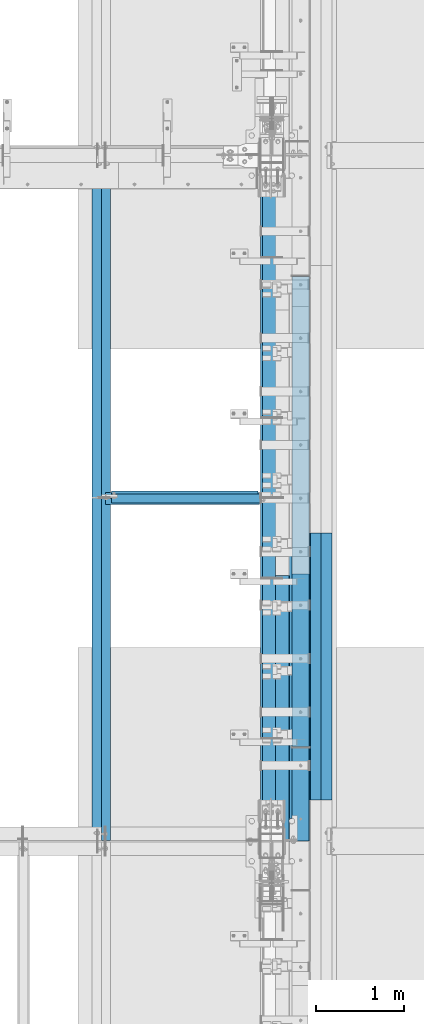
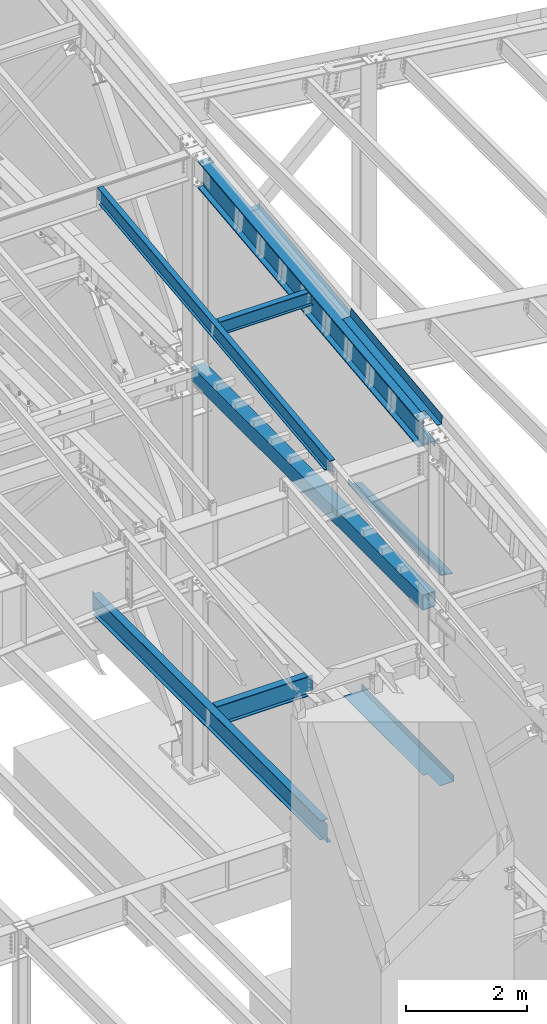
# One storey, part 736 of 1179: 12 beams, 10 elements without a shape of their own.
"""IFC2X3 building model written with IfcOpenShell, lengths in millimetres."""

from ifc_helpers import new_model, si_unit, frame, origin_with_axes, place, context, subcontext, project, spatial, faceted_brep, material, type_object, element, aggregate, save


model = new_model("IFC2X3")

# Units and contexts
model_context = context("Model", 3, precision=1e-05, world=origin_with_axes())
body_context = subcontext(model_context, "Body", "Model", "MODEL_VIEW")
ifc_project = project(units=[si_unit("LENGTHUNIT", "METRE", prefix="MILLI"), si_unit("AREAUNIT", "SQUARE_METRE"), si_unit("VOLUMEUNIT", "CUBIC_METRE"), si_unit("MASSUNIT", "GRAM", prefix="KILO"), si_unit("TIMEUNIT", "SECOND"), si_unit("PLANEANGLEUNIT", "RADIAN"), si_unit("SOLIDANGLEUNIT", "STERADIAN"), si_unit("THERMODYNAMICTEMPERATUREUNIT", "DEGREE_CELSIUS"), si_unit("LUMINOUSINTENSITYUNIT", "LUMEN")], contexts=[model_context])

# Site, building, storey
site_placement = place(None, origin_with_axes())
site = spatial("IfcSite", under=ifc_project, at=site_placement, CompositionType="ELEMENT")
building_placement = place(site_placement, origin_with_axes())
building = spatial("IfcBuilding", under=site, at=building_placement, Name="Undefined", CompositionType="ELEMENT")
storey_placement = place(building_placement, origin_with_axes())
storey = spatial("IfcBuildingStorey", under=building, at=storey_placement, Name="Undefined", CompositionType="ELEMENT", Elevation=0.0)

# Assembly, beam
assembly_1_placement = place(storey_placement, origin_with_axes())
assembly_1 = element("IfcElementAssembly", 1, at=assembly_1_placement, inside=storey, Name="BEAM", AssemblyPlace="NOTDEFINED", PredefinedType="RIGID_FRAME")
ifc_material_1 = material(Name="STEEL/A992")
beam_type_1 = type_object("IfcBeamType", Name="W16X31", PredefinedType="NOTDEFINED")
beam_1_placement = place(assembly_1_placement, frame((22329.775, 23139.4, 3900.4875), z_axis=(0.0, 0.0, 1.0), x_axis=(1.0, 0.0, 0.0)))
beam_1 = element("IfcBeam", 2, at=beam_1_placement, type_object=beam_type_1, material=ifc_material_1, Name="BEAM", ObjectType="W16X31", context=body_context, shape_type="Brep", body=[
    faceted_brep([(12.7000000000007, -3.17499999999927, -169.8625), (12.7000000000007, 3.17499999999927, -169.8625), (66.6750001907276, 3.17499999999927, -169.8625), (66.6750001907276, -3.17499999999927, -169.8625), (71.535079708774, 3.17499999999927, -170.829229922588), (71.535079708774, -3.17499999999927, -170.829229922588), (75.6552561769277, 3.17499999999927, -173.582243823066), (75.6552561769277, -3.17499999999927, -173.582243823066), (78.4082700774052, 3.17499999999927, -177.70242029122), (78.4082700774052, -3.17499999999927, -177.70242029122), (79.3749999999927, -3.17499999999927, -182.562499809265), (79.3749999999927, 3.17499999999927, -182.562499809265), (79.3749999999927, 3.17499999999927, -190.5), (79.3749999999927, 69.8499999999985, -190.5), (79.3749999999927, 69.8499999999985, -201.6125), (79.3749999999927, -69.8499999999985, -201.6125), (79.3749999999927, -69.8499999999985, -190.5), (79.3749999999927, -3.17499999999927, -190.5), (1835.94375, 69.8499999999985, 190.5), (1835.94375, 3.17499999999927, 190.5), (79.3749999999927, 3.17499999999927, 190.5), (79.3749999999927, 69.8499999999985, 190.5), (66.6750001907276, -3.17499999999927, 169.8625), (66.6750001907276, 3.17499999999927, 169.8625), (12.7000000000007, 3.17499999999927, 169.8625), (12.7000000000007, -3.17499999999927, 169.8625), (71.535079708774, -3.17499999999927, 170.829229922588), (71.535079708774, 3.17499999999927, 170.829229922588), (75.6552561769277, -3.17499999999927, 173.582243823066), (75.6552561769277, 3.17499999999927, 173.582243823066), (78.4082700774052, -3.17499999999927, 177.702420291219), (78.4082700774052, 3.17499999999927, 177.702420291219), (79.3749999999927, -3.17499999999927, 182.562499809265), (79.3749999999927, 3.17499999999927, 182.562499809265), (1835.94375, -69.8499999999985, 201.6125), (1835.94375, 69.8499999999985, 201.6125), (79.3749999999927, 69.8499999999985, 201.6125), (79.3749999999927, -69.8499999999985, 201.6125), (1835.94375, -69.8499999999985, 190.5), (79.3749999999927, -69.8499999999985, 190.5), (1835.94375, -3.17499999999927, 190.5), (79.3749999999927, -3.17499999999927, 190.5), (1835.94375, -3.17499999999927, 169.862499809265), (1835.94375, 3.17499999999927, 169.862499809265), (1836.91047992259, -3.17499999999927, 165.00242029122), (1836.91047992259, 3.17499999999927, 165.00242029122), (1839.66349382306, -3.17499999999927, 160.882243823066), (1839.66349382306, 3.17499999999927, 160.882243823066), (1843.78367029122, -3.17499999999927, 158.129229922588), (1843.78367029122, 3.17499999999927, 158.129229922588), (1848.64374980926, -3.17499999999927, 157.1625), (1848.64374980926, 3.17499999999927, 157.1625), (1959.76875, -3.17499999999927, 157.1625), (1959.76875, 3.17499999999927, 157.1625), (1959.76875, -3.17499999999927, -157.1625), (1959.76875, 3.17499999999927, -157.1625), (1848.64374980926, -3.17499999999927, -157.1625), (1848.64374980926, 3.17499999999927, -157.1625), (1843.78367029122, -3.17499999999927, -158.129229922588), (1843.78367029122, 3.17499999999927, -158.129229922588), (1839.66349382306, -3.17499999999927, -160.882243823066), (1839.66349382306, 3.17499999999927, -160.882243823066), (1836.91047992259, -3.17499999999927, -165.00242029122), (1836.91047992259, 3.17499999999927, -165.00242029122), (1835.94375, -3.17499999999927, -169.862499809266), (1835.94375, 3.17499999999927, -169.862499809266), (1835.94375, -3.17499999999927, -190.5), (1835.94375, -69.8499999999985, -190.5), (1835.94375, -69.8499999999985, -201.6125), (1835.94375, 69.8499999999985, -201.6125), (1835.94375, 69.8499999999985, -190.5), (1835.94375, 3.17499999999927, -190.5)], [[[0, 1, 2, 3]], [[3, 2, 4, 5]], [[5, 4, 6, 7]], [[7, 6, 8, 9]], [[10, 11, 12, 13, 14, 15, 16, 17]], [[9, 8, 11, 10]], [[18, 19, 20, 21]], [[22, 23, 24, 25]], [[26, 27, 23, 22]], [[28, 29, 27, 26]], [[30, 31, 29, 28]], [[32, 33, 31, 30]], [[34, 35, 36, 37]], [[38, 34, 37, 39]], [[40, 38, 39, 41]], [[37, 36, 21, 20, 33, 32, 41, 39]], [[35, 18, 21, 36]], [[34, 38, 40, 42, 43, 19, 18, 35]], [[44, 45, 43, 42]], [[46, 47, 45, 44]], [[48, 49, 47, 46]], [[50, 51, 49, 48]], [[52, 53, 51, 50]], [[53, 52, 54, 55]], [[54, 56, 57, 55]], [[58, 59, 57, 56]], [[60, 61, 59, 58]], [[62, 63, 61, 60]], [[64, 65, 63, 62]], [[66, 67, 68, 69, 70, 71, 65, 64]], [[67, 66, 17, 16]], [[68, 67, 16, 15]], [[69, 68, 15, 14]], [[70, 69, 14, 13]], [[71, 70, 13, 12]], [[6, 4, 2, 1, 24, 23, 27, 29, 31, 33, 20, 19, 43, 45, 47, 49, 51, 53, 55, 57, 59, 61, 63, 65, 71, 12, 11, 8]], [[25, 24, 1, 0]], [[66, 64, 62, 60, 58, 56, 54, 52, 50, 48, 46, 44, 42, 40, 41, 32, 30, 28, 26, 22, 25, 0, 3, 5, 7, 9, 10, 17]]]),
])
aggregate(assembly_1, [beam_1])

assembly_2_placement = place(storey_placement, origin_with_axes())
assembly_2 = element("IfcElementAssembly", 3, at=assembly_2_placement, inside=storey, Name="BEAM", AssemblyPlace="NOTDEFINED", PredefinedType="RIGID_FRAME")
beam_2_placement = place(assembly_2_placement, frame((22326.6, 19227.8, 3900.4875), z_axis=(0.0, 0.0, 1.0), x_axis=(0.0, 1.0, 0.0)))
beam_2 = element("IfcBeam", 4, at=beam_2_placement, type_object=beam_type_1, material=ifc_material_1, Name="BEAM", ObjectType="W16X31", context=body_context, shape_type="Brep", body=[
    faceted_brep([(113.506251936145, -3.17499999997744, 169.8625), (113.506251936145, 3.17496422017757, 169.8625), (18.2562514952835, 3.17499999999927, 169.8625), (18.2562514952835, -3.17499999999927, 169.8625), (118.366331454192, -3.17499999997926, 170.829229922588), (118.366331454192, 3.17496349569046, 170.829229922588), (122.486507922345, -3.17499999997744, 173.582243823066), (122.486507922345, 3.17496143253265, 173.582243823066), (125.239521822827, -3.17499999997563, 177.70242029122), (125.239521822819, 3.17495834479632, 177.70242029122), (126.206251745411, -3.17499999997744, 182.562499809265), (126.206251745411, 3.1749547025629, 182.562499809265), (126.206251745432, -69.8499999999767, 201.6125), (126.206251745396, 69.850000000024, 201.6125), (126.206251745396, 69.850000000024, 190.5), (126.206251745418, 3.17500000002292, 190.5), (126.206251745411, -3.17499999997744, 190.5), (126.206251745432, -69.8499999999767, 190.5), (7677.15000000001, 3.17499999999927, -190.5), (7677.15000000001, 69.8499999999985, -190.5), (145.256250000001, 69.8499999999985, -190.5), (145.256250000001, 3.17549991607666, -190.5), (18.2562500000006, -3.17500000000291, -190.5), (18.2562500000006, -69.8499999999985, -190.5), (7804.15, -69.8499999999985, -190.5), (7804.15, -3.17499999999927, -190.5), (18.2562500000006, -69.8499999999985, -201.612499999999), (7804.15, -69.8499999999985, -201.6125), (7677.15000000001, 69.8499999999985, -201.6125), (7677.15000000001, 3.17549991607666, -201.6125), (7804.15, 3.17549991607666, -201.6125), (18.2562500000006, 3.17549991607666, -201.612499999999), (145.256250000001, 3.17549991607666, -201.612499999999), (145.256250000001, 69.8499999999985, -201.612499999999), (18.2562500000006, 3.17500000000291, -190.5), (7804.15, 3.17499999999927, -190.5), (7804.15, 3.17499999999927, 169.8625), (7804.15, -3.17499999999927, 169.8625), (7708.89999980925, 3.17499999999927, 169.8625), (7708.89999980925, -3.17499999999927, 169.8625), (7704.03992029121, 3.17499999999927, 170.829229922588), (7704.03992029121, -3.17499999999927, 170.829229922588), (7699.91974382305, 3.17499999999927, 173.582243823066), (7699.91974382305, -3.17499999999927, 173.582243823066), (7697.16672992258, 3.17499999999927, 177.70242029122), (7697.16672992258, -3.17499999999927, 177.70242029122), (7696.19999999999, 3.17499999999927, 182.562499809265), (7696.19999999999, -3.17499999999927, 182.562499809265), (7696.19999999999, -69.8499999999985, 201.6125), (7696.19999999999, -69.8499999999985, 190.5), (7696.19999999999, -3.17499999999927, 190.5), (7696.19999999999, 3.17499999999927, 190.5), (7696.19999999999, 69.8499999999985, 190.5), (7696.19999999999, 69.8499999999985, 201.6125)], [[[0, 1, 2, 3]], [[4, 5, 1, 0]], [[6, 7, 5, 4]], [[8, 9, 7, 6]], [[10, 11, 9, 8]], [[12, 13, 14, 15, 11, 10, 16, 17]], [[18, 19, 20, 21]], [[22, 23, 24, 25]], [[23, 26, 27, 24]], [[28, 29, 30, 27, 26, 31, 32, 33]], [[21, 32, 31, 34]], [[20, 33, 32, 21]], [[19, 28, 33, 20]], [[18, 29, 28, 19]], [[35, 30, 29, 18]], [[25, 24, 27, 30, 35, 36, 37]], [[37, 36, 38, 39]], [[39, 38, 40, 41]], [[41, 40, 42, 43]], [[43, 42, 44, 45]], [[45, 44, 46, 47]], [[48, 49, 50, 47, 46, 51, 52, 53]], [[49, 48, 12, 17]], [[50, 49, 17, 16]], [[8, 6, 4, 0, 3, 22, 25, 37, 39, 41, 43, 45, 47, 50, 16, 10]], [[34, 31, 26, 23, 22, 3, 2]], [[51, 46, 44, 42, 40, 38, 36, 35, 18, 21, 34, 2, 1, 5, 7, 9, 11, 15]], [[52, 51, 15, 14]], [[53, 52, 14, 13]], [[48, 53, 13, 12]]]),
])
aggregate(assembly_2, [beam_2])

# Assembly, beams
assembly_3_placement = place(storey_placement, origin_with_axes())
assembly_3 = element("IfcElementAssembly", 5, at=assembly_3_placement, inside=storey, Name="BEAM", AssemblyPlace="NOTDEFINED", PredefinedType="RIGID_FRAME")
ifc_material_2 = material(Name="STEEL/A36")
beam_type_2 = type_object("IfcBeamType", PredefinedType="NOTDEFINED")
beam_3_placement = place(assembly_3_placement, frame((24350.663, 20744.8759537219, 11594.2188079249), z_axis=(0.0, -0.993676146336441, -0.112284087038017), x_axis=(1.0, 0.0, 0.0)))
beam_3 = element("IfcBeam", 6, at=beam_3_placement, type_object=beam_type_2, material=ifc_material_2, Name="BENT_PLATE", context=body_context, shape_type="Brep", body=[
    faceted_brep([(71.4364017397384, -3.17373043168664, 1106.32182867605), (71.4364359189567, 3.17500000044492, 1106.32310852323), (0.0, 3.17500000044492, 1106.32312278878), (0.0, -3.17499999954998, 1106.32184301913), (71.4359197604317, -3.2579531269057, 1524.11170893996), (71.4359543929495, 3.17500000061591, 1523.99999999914), (160.337000000047, -3.17500000061591, -1523.99999999915), (0.0, -3.17499999999927, -1524.0), (0.0, 3.17499999999927, -1524.0), (153.987000022519, 3.17500000077052, -1524.00000000059), (153.987000000016, 187.324999998867, -1523.99999999923), (160.337000000014, 187.324999998867, -1523.99999999923), (153.987000024775, 3.17499999922438, 1524.00000000046), (153.987000000016, 187.325000000103, 1523.99999999907), (160.337000000014, 187.325000000103, 1523.99999999907), (160.336999999981, -3.17499999938082, 1523.99999999915)], [[[0, 1, 2, 3]], [[4, 5, 1, 0]], [[6, 7, 8, 9, 10, 11]], [[9, 12, 13, 10]], [[14, 11, 10, 13]], [[15, 6, 11, 14]], [[3, 7, 6, 15, 4, 0]], [[8, 7, 3, 2]], [[12, 9, 8, 2, 1, 5]], [[15, 14, 13, 12, 5, 4]]]),
])
beam_type_3 = type_object("IfcBeamType", PredefinedType="NOTDEFINED")
beam_4_placement = place(assembly_3_placement, frame((24350.6629997716, 21002.8689489845, 11094.5656952317), z_axis=(0.0, -0.993676146336441, -0.112284087038017), x_axis=(1.0, 0.0, 0.0)))
beam_4 = element("IfcBeam", 7, at=beam_4_placement, type_object=beam_type_3, material=ifc_material_2, Name="BENT_PLATE", context=body_context, shape_type="Brep", body=[
    faceted_brep([(76.1995002278854, -3.09349136783021, 473.728949061853), (76.1995002278854, 3.25712224588824, 473.728949064349), (-3.63797880709171e-12, 3.17500000019027, 473.728949064349), (-3.63797880709171e-12, -3.17499999980464, 473.728949061853), (76.1995002278854, -3.09395313298774, 607.078949063987), (76.1995002278854, 3.25666048072708, 607.078949066421), (-7.27595761418343e-12, -3.17499999975007, 607.078949063987), (-7.27595761418343e-12, 3.17500000024484, 607.078949066421), (179.387000000001, -3.17499999999927, 1524.0), (179.387000000001, -3.17499999999927, -1524.0), (179.387000202249, -136.524999793119, -1523.99999999991), (179.38700020294, -136.524999792508, 1523.99999999976), (76.1995002269396, -3.17510786902676, 1377.94999996143), (76.1995002269396, 3.17550574472261, 1377.94999996396), (7.27595761418343e-12, 3.17500000055588, 1377.94999996396), (7.27595761418343e-12, -3.1749999994372, 1377.94999996142), (76.1995002269396, -3.17561361185653, 1523.999999945), (76.1995002269396, 3.17500000061045, 1523.99999999914), (185.737000202938, -136.524999792508, 1523.99999999976), (185.737000000001, 3.17499999999927, 1524.0), (185.737000000001, 3.17499999999927, -1524.0), (185.737000202247, -136.524999793119, -1523.99999999991), (0.0, -3.17499999999927, -1524.0), (0.0, 3.17499999999927, -1524.0), (1.09139364212751e-11, -3.17500000039763, -987.323978428016), (1.09139364212751e-11, 3.17499999960091, -987.323978425524), (76.1995002278854, -3.09349136842684, -987.323978428012), (76.1995002278854, 3.25712224529343, -987.32397842552), (76.1995002278854, -3.09395313358254, -853.973978425882), (76.1995002278854, 3.25666048013227, -853.973978423448), (7.27595761418343e-12, -3.17500000034306, -853.973978425885), (7.27595761418343e-12, 3.17499999965366, -853.973978423452), (3.63797880709171e-12, -3.17500000010114, -256.79751468396), (3.63797880709171e-12, 3.17499999989559, -256.797514681464), (76.1995002278854, -3.0934913681358, -256.797514683956), (76.1995002278854, 3.25712224558447, -256.797514681468), (76.1995002278854, -3.09395313329333, -123.447514681826), (76.1995002278854, 3.25666048042513, -123.447514679392), (0.0, -3.17500000004839, -123.447514681826), (0.0, 3.17499999994652, -123.447514679392)], [[[0, 1, 2, 3]], [[4, 5, 1, 0]], [[6, 7, 5, 4]], [[8, 9, 10, 11]], [[12, 13, 14, 15]], [[16, 17, 13, 12]], [[8, 11, 18, 19, 17, 16]], [[20, 19, 18, 21]], [[11, 10, 21, 18]], [[9, 22, 23, 20, 21, 10]], [[23, 22, 24, 25]], [[26, 27, 25, 24]], [[28, 29, 27, 26]], [[30, 31, 29, 28]], [[32, 33, 31, 30]], [[34, 35, 33, 32]], [[36, 37, 35, 34]], [[38, 39, 37, 36]], [[39, 38, 3, 2]], [[14, 13, 17, 19, 20, 23, 25, 27, 29, 31, 33, 35, 37, 39, 2, 1, 5, 7]], [[15, 14, 7, 6]], [[3, 38, 36, 34, 32, 30, 28, 26, 24, 22, 9, 8, 16, 12, 15, 6, 4, 0]]]),
])

# Assembly, beam
assembly_4_placement = place(storey_placement, origin_with_axes())
assembly_4 = element("IfcElementAssembly", 8, at=assembly_4_placement, inside=storey, Name="PLATE", AssemblyPlace="NOTDEFINED", PredefinedType="RIGID_FRAME")
beam_type_4 = type_object("IfcBeamType", PredefinedType="NOTDEFINED")
beam_5_placement = place(assembly_4_placement, frame((24880.9652345644, 19697.6999999996, 7964.0487255808), z_axis=(-0.99100656978554, 0.0, 0.133813222971043), x_axis=(0.0, 1.0, 0.0)))
beam_5 = element("IfcBeam", 9, at=beam_5_placement, type_object=beam_type_4, material=ifc_material_2, Name="PLATE", context=body_context, shape_type="Brep", body=[
    faceted_brep([(0.0, 4.76249999999709, -114.3), (0.0, 4.76249999999709, 114.3), (3048.0, 4.76249999996799, 114.300000000025), (3048.0, 4.76250000002983, -114.300000000025), (0.0, -4.76249999999709, 114.3), (3048.0, -4.76250000003711, 114.300000000014), (0.0, -4.76249999999709, -114.3), (3048.0, -4.76249999997344, -114.300000000036)], [[[0, 1, 2, 3]], [[1, 4, 5, 2]], [[4, 6, 7, 5]], [[6, 0, 3, 7]], [[5, 7, 3, 2]], [[6, 4, 1, 0]]]),
])
aggregate(assembly_4, [beam_5])

assembly_5_placement = place(storey_placement, origin_with_axes())
assembly_5 = element("IfcElementAssembly", 10, at=assembly_5_placement, inside=storey, Name="BEAM", AssemblyPlace="NOTDEFINED", PredefinedType="RIGID_FRAME")
beam_type_5 = type_object("IfcBeamType", PredefinedType="NOTDEFINED")
beam_6_placement = place(assembly_5_placement, frame((24387.175012207, 20754.975, 4105.275), z_axis=(0.0, -1.0, 0.0), x_axis=(1.0, 0.0, 0.0)))
beam_6 = element("IfcBeam", 11, at=beam_6_placement, type_object=beam_type_5, material=ifc_material_2, Name="BENT_PLATE", context=body_context, shape_type="Brep", body=[
    faceted_brep([(84.1374893188477, -3.17500000000018, 1120.775), (84.1374893188477, 3.17500000000018, 1120.775), (0.0, 3.17500000000018, 1120.775), (0.0, -3.17500000000018, 1120.775), (84.1374893188477, -3.17500000000018, 1524.0), (84.1374893188477, 3.17500000000018, 1524.0), (352.424987792969, -3.17499999999927, -1524.0), (0.0, -3.17499999999927, -1524.0), (0.0, 3.17499999999927, -1524.0), (346.07498779297, 3.17500000000109, -1524.0), (346.07498779297, 130.175006103515, -1524.0), (352.424987792969, 130.175006103515, -1524.0), (346.07498779297, 3.17500000000109, 1524.0), (346.07498779297, 130.175006103515, 1524.0), (352.424987792969, 130.175006103515, 1524.0), (352.424987792969, -3.17499999999927, 1524.0)], [[[0, 1, 2, 3]], [[4, 5, 1, 0]], [[6, 7, 8, 9, 10, 11]], [[9, 12, 13, 10]], [[14, 11, 10, 13]], [[15, 6, 11, 14]], [[3, 7, 6, 15, 4, 0]], [[8, 7, 3, 2]], [[12, 9, 8, 2, 1, 5]], [[15, 14, 13, 12, 5, 4]]]),
])
aggregate(assembly_5, [beam_6])

assembly_6_placement = place(storey_placement, origin_with_axes())
assembly_6 = element("IfcElementAssembly", 12, at=assembly_6_placement, inside=storey, Name="BEAM", AssemblyPlace="NOTDEFINED", PredefinedType="RIGID_FRAME")
ifc_material_3 = material()
beam_type_6 = type_object("IfcBeamType", Name="HSS8X8X1/4", PredefinedType="NOTDEFINED")
beam_7_placement = place(assembly_6_placement, frame((24638.0, 20294.5999999686, 11181.5347858005), z_axis=(0.0, -0.112396759996816, 0.993663407971843), x_axis=(0.0, 0.993663407971844, 0.112396759996815)))
beam_7 = element("IfcBeam", 13, at=beam_7_placement, type_object=beam_type_6, material=ifc_material_3, Name="BEAM", ObjectType="HSS8X8X1/4", context=body_context, shape_type="Brep", body=[
    faceted_brep([(5424.24071128941, -101.599999999999, 101.599999996108), (5424.24071128941, 101.599999999999, 101.599999996108), (17.8828269946353, 101.599999999999, 101.599999999928), (17.8828269946353, -101.599999999999, 101.599999999928), (5401.2560452062, -101.599999999999, -101.600000003755), (-5.10183908856925, -101.599999999999, -101.599999999935), (5401.2560452062, 101.599999999999, -101.600000003755), (-5.10183908856925, 101.599999999999, -101.599999999935), (5423.52244047431, -95.25, 95.249999996111), (5423.52244047431, 95.25, 95.249999996111), (5401.9743160213, 95.25, -95.2500000037599), (5401.9743160213, -95.25, -95.2500000037599), (17.1645561795376, -95.25, 95.2499999999327), (17.1645561795376, 95.25, 95.2499999999327), (-4.38356827347161, 95.25, -95.2499999999382), (-4.38356827347161, -95.25, -95.2499999999382)], [[[0, 1, 2, 3]], [[4, 0, 3, 5]], [[6, 4, 5, 7]], [[1, 6, 7, 2]], [[0, 4, 6, 1], [8, 9, 10, 11]], [[9, 8, 12, 13]], [[10, 9, 13, 14]], [[11, 10, 14, 15]], [[8, 11, 15, 12]], [[7, 5, 3, 2], [14, 13, 12, 15]]]),
])
aggregate(assembly_6, [beam_7])

assembly_7_placement = place(storey_placement, origin_with_axes())
assembly_7 = element("IfcElementAssembly", 14, at=assembly_7_placement, inside=storey, Name="BENT_PLATE", AssemblyPlace="NOTDEFINED", PredefinedType="RIGID_FRAME")
beam_type_7 = type_object("IfcBeamType", PredefinedType="NOTDEFINED")
beam_8_placement = place(assembly_7_placement, frame((24744.362499997, 21221.6999999996, 8102.29217706219), z_axis=(0.0, 1.0, 0.0), x_axis=(0.0, 0.0, -1.0)))
beam_8 = element("IfcBeam", 15, at=beam_8_placement, type_object=beam_type_7, material=ifc_material_2, Name="BENT_PLATE", context=body_context, shape_type="Brep", body=[
    faceted_brep([(-2.91038304567337e-11, -4.76250000000073, -1524.0), (-2.91038304567337e-11, -4.76250000000073, 1524.0), (2.91038304567337e-11, 4.76250000000073, 1524.0), (2.91038304567337e-11, 4.76250000000073, -1524.0), (114.300008765535, 4.76250001759399, 1524.0000000001), (114.300003051474, 4.7625000005828, -1524.0), (105.977955544956, -4.76249999945867, -1524.0), (105.977955544956, -4.76249999945867, 1524.0), (131.343048095475, -121.088742065571, 1524.0), (131.343048095475, -121.088742065571, -1524.0), (121.904205090902, -122.366970423507, 1524.0), (121.904205090902, -122.366970423507, -1524.0)], [[[0, 1, 2, 3]], [[3, 2, 4, 5]], [[1, 0, 6, 7]], [[5, 4, 8, 9]], [[4, 2, 1, 7, 10, 8]], [[7, 6, 11, 10]], [[6, 0, 3, 5, 9, 11]], [[10, 11, 9, 8]]]),
])
aggregate(assembly_7, [beam_8])

assembly_8_placement = place(storey_placement, origin_with_axes())
assembly_8 = element("IfcElementAssembly", 16, at=assembly_8_placement, inside=storey, Name="BEAM", AssemblyPlace="NOTDEFINED", PredefinedType="RIGID_FRAME")
beam_type_8 = type_object("IfcBeamType", Name="W12X22", PredefinedType="NOTDEFINED")
beam_9_placement = place(assembly_8_placement, frame((22415.5, 23156.8779321476, 11707.011532693), z_axis=(0.0, -0.112284087038017, 0.993676146336441), x_axis=(1.0, 0.0, 0.0)))
beam_9 = element("IfcBeam", 17, at=beam_9_placement, type_object=beam_type_8, material=ifc_material_1, Name="BEAM", ObjectType="W12X22", context=body_context, shape_type="Brep", body=[
    faceted_brep([(1770.85625, -50.799999999901, 155.574999999935), (1770.85625, -50.7999999999047, 144.462499999941), (1770.85625, -3.17499999993379, 144.462499999923), (1770.85625, -3.17499999993743, 130.174999807548), (1770.85625, 3.17500000005748, 130.174999807547), (1770.85625, 3.17500000006476, 144.462499999918), (1770.85625, 50.8000000000357, 144.4624999999), (1770.85625, 50.8000000000429, 155.574999999893), (1771.82297992259, -3.17499999993743, 125.314920289511), (1771.82297992259, 3.17500000005748, 125.314920289509), (1774.57599382307, -3.1749999999447, 121.194743821365), (1774.57599382307, 3.17500000005384, 121.194743821363), (1778.69617029122, -3.1749999999447, 118.441729920891), (1778.69617029122, 3.17500000005384, 118.441729920889), (1783.55624980927, -3.1749999999447, 117.474999998307), (1783.55624980927, 3.17500000005384, 117.474999998303), (1872.45625, -3.1749999999447, 117.474999998307), (1872.45625, 3.17500000005384, 117.474999998303), (63.5, -50.799999999901, 155.574999999935), (63.5, 50.8000000000429, 155.574999999893), (63.5, 50.8000000000357, 144.4624999999), (63.5, 3.17500000006476, 144.462499999918), (63.5, 3.1750000039101, 142.874999807529), (63.5, -3.17499999993015, 142.874999807531), (63.5, -3.17499999993379, 144.462499999923), (63.5, -50.7999999999047, 144.462499999941), (62.5332700774125, 3.17500000353539, 138.014920289492), (62.5332700774125, -3.17499999993379, 138.014920289494), (59.7802561769349, 3.17500000321525, 133.894743821344), (59.7802561769349, -3.17499999993743, 133.894743821347), (55.6600797087813, 3.17500000300424, 131.141729920872), (55.6600797087813, -3.17499999993379, 131.141729920873), (50.8000001907349, 3.17500000292785, 130.174999998286), (50.8000001907349, -3.17499999994106, 130.174999998288), (15.875, 3.17500000005748, 130.174999998284), (15.875, -3.17499999994106, 130.174999998288), (15.875, 3.17499999995198, -130.175000001278), (15.875, -3.17500000004293, -130.175000001276), (50.8000001907349, 3.17499998291896, -130.175000001278), (50.8000001907349, -3.17500000004293, -130.175000001276), (55.6600797087813, 3.17499998284256, -131.141729923866), (55.6600797087813, -3.17500000004293, -131.141729923862), (59.7802561769349, 3.17499998263156, -133.894743824338), (59.7802561769349, -3.17500000004293, -133.894743824334), (62.5332700774125, 3.17499998230778, -138.014920292484), (62.5332700774125, -3.17500000004657, -138.014920292482), (63.5, 3.17499998193671, -142.874999810523), (63.5, -3.17500000004657, -142.874999810521), (1732.75625, 3.17499999994834, -144.46249999992), (1732.75625, 50.7999999999192, -144.46249999994), (63.5, 50.7999999999192, -144.46249999994), (63.5, 3.17499995250182, -144.46249999992), (1732.75625, 50.7999999999156, -155.574999999932), (63.5, 50.7999999999156, -155.574999999932), (1732.75625, 3.17499999999563, -155.574999999912), (1872.45625, 3.17499999994834, -144.46249999992), (1872.45625, 3.17499999999563, -155.574999999912), (1872.45625, -50.8000000000284, -155.574999999892), (63.5, -50.8000000000284, -155.574999999892), (1872.45625, -50.8000000000247, -144.462499999896), (63.5, -50.8000000000247, -144.462499999896), (63.5, -3.1750000000502, -144.462499999914), (1872.45625, -3.1750000000502, -144.462499999914)], [[[0, 1, 2, 3, 4, 5, 6, 7]], [[8, 9, 4, 3]], [[10, 11, 9, 8]], [[12, 13, 11, 10]], [[14, 15, 13, 12]], [[16, 17, 15, 14]], [[18, 19, 20, 21, 22, 23, 24, 25]], [[23, 22, 26, 27]], [[27, 26, 28, 29]], [[29, 28, 30, 31]], [[31, 30, 32, 33]], [[33, 32, 34, 35]], [[35, 34, 36, 37]], [[37, 36, 38, 39]], [[39, 38, 40, 41]], [[41, 40, 42, 43]], [[43, 42, 44, 45]], [[45, 44, 46, 47]], [[48, 49, 50, 51]], [[49, 52, 53, 50]], [[48, 54, 52, 49]], [[55, 56, 54, 48]], [[52, 54, 56, 57, 58, 53]], [[57, 59, 60, 58]], [[47, 46, 51, 50, 53, 58, 60, 61]], [[59, 62, 61, 60]], [[62, 16, 14, 12, 10, 8, 3, 2, 24, 23, 27, 29, 31, 33, 35, 37, 39, 41, 43, 45, 47, 61]], [[2, 1, 25, 24]], [[1, 0, 18, 25]], [[0, 7, 19, 18]], [[7, 6, 20, 19]], [[6, 5, 21, 20]], [[42, 40, 38, 36, 34, 32, 30, 28, 26, 22, 21, 5, 4, 9, 11, 13, 15, 17, 55, 48, 51, 46, 44]], [[62, 59, 57, 56, 55, 17, 16]]]),
])
aggregate(assembly_8, [beam_9])

assembly_9_placement = place(storey_placement, origin_with_axes())
assembly_9 = element("IfcElementAssembly", 18, at=assembly_9_placement, inside=storey, Name="BEAM", AssemblyPlace="NOTDEFINED", PredefinedType="RIGID_FRAME")
beam_10_placement = place(assembly_9_placement, frame((22415.5, 19245.2779321397, 11265.0059190149), z_axis=(0.0, -0.112284087038017, 0.993676146336441), x_axis=(0.0, 0.993676146336441, 0.112284087038017)))
beam_10 = element("IfcBeam", 19, at=beam_10_placement, type_object=beam_type_8, material=ifc_material_1, Name="BEAM", ObjectType="W12X22", context=body_context, shape_type="Brep", body=[
    faceted_brep([(7676.8057846648, 3.17499999999927, -144.462500003032), (7676.80578466482, 3.17490308365814, -155.575000003026), (7676.80577856895, 50.7999999999993, -155.575000003026), (7676.80577856896, 50.7999999999993, -144.462500003034), (7820.7019525921, 3.17499999999927, -144.462500003092), (7819.44625482597, 3.17492134140048, -155.575000003084), (5.12531926095107, 3.17499999999927, 144.46249999992), (5.12531926095107, 50.7999999999993, 144.46249999992), (7757.4939140051, 50.7999999999993, 144.462499996773), (7757.4939140051, 3.17499999999927, 144.462499996773), (5.12531926095107, -3.17499999999927, 144.46249999992), (5.12531926095107, -50.7999999999993, 144.46249999992), (6.38101702707718, -50.7999999999993, 155.574999999912), (6.38101702707718, 50.7999999999993, 155.574999999912), (-25.0621566261689, 3.17499999999927, -122.686438896275), (-25.0621566261689, -3.17499999999927, -122.686438896275), (145.312894957096, 3.17499999999927, -141.93859400049), (145.312894957096, -3.17499999999927, -141.93859400049), (145.027696926005, -3.17499999999927, -144.462499999976), (145.027696926005, -50.7999999999993, -144.462499999976), (7676.805791578, -50.7999999999993, -144.462500003034), (7676.805785482, -3.17499999999927, -144.462500003032), (145.027696926005, 3.17499999999927, -144.462499999976), (145.027696926005, 50.7999999999993, -144.462499999976), (143.771999161854, 50.7999999999993, -155.574999999972), (143.771999161854, -50.7999999999993, -155.574999999972), (7676.805791578, -50.7999999999993, -155.575000003026), (7676.80578548203, -3.17509692720705, -155.575000003026), (7820.7019525921, -3.17499999999927, -144.462500003092), (7819.44625482597, -3.17507866903179, -155.575000003084), (7760.28182167741, -3.17499999999927, 99.3123538561285), (7756.49682025474, -3.17499999999927, 102.510588352729), (7754.22384626446, -3.17499999999927, 106.91382908024), (7753.80893939206, -3.17499999999927, 111.851722553385), (7757.4939140051, -3.17499999999927, 144.462499996773), (7821.50556176969, -3.17499999999927, -137.350830916108), (7847.03058449439, -3.17499999999927, 88.5369763886902), (7765.00261837702, -3.17499999999927, 97.8060278004923), (7757.4939140051, -50.7999999999993, 144.462499996773), (7758.74961177122, -50.7999999999993, 155.574999996767), (7758.74961177122, 50.7999999999993, 155.574999996767), (7753.80893939206, 3.17499999999927, 111.851722553385), (7754.22384626446, 3.17499999999927, 106.91382908024), (7756.49682025474, 3.17499999999927, 102.510588352729), (7760.28182167741, 3.17499999999927, 99.3123538561285), (7765.00261837702, 3.17499999999927, 97.8060278004923), (7847.03058449439, 3.17499999999927, 88.5369763886902), (7821.50554925474, 3.17499999999927, -137.350941669098)], [[[0, 1, 2, 3]], [[4, 5, 1, 0]], [[6, 7, 8, 9]], [[10, 11, 12, 13, 7, 6, 14, 15]], [[15, 14, 16, 17]], [[18, 19, 20, 21]], [[17, 16, 22, 23, 24, 25, 19, 18]], [[19, 25, 26, 20]], [[20, 26, 27, 21]], [[28, 21, 27, 29]], [[30, 31, 32, 33, 34, 10, 15, 17, 18, 21, 28, 35, 36, 37]], [[11, 10, 34, 38]], [[12, 11, 38, 39]], [[13, 12, 39, 40]], [[7, 13, 40, 8]], [[39, 38, 34, 33, 41, 9, 8, 40]], [[32, 42, 41, 33]], [[31, 43, 42, 32]], [[30, 44, 43, 31]], [[37, 45, 44, 30]], [[36, 46, 45, 37]], [[47, 4, 0, 22, 16, 14, 6, 9, 41, 42, 43, 44, 45, 46]], [[23, 22, 0, 3]], [[24, 23, 3, 2]], [[29, 27, 26, 25, 24, 2, 1, 5]], [[47, 46, 36, 35, 28, 29, 5, 4]]]),
])
aggregate(assembly_9, [beam_10])

# Beam
beam_type_9 = type_object("IfcBeamType", Name="W21X93", PredefinedType="NOTDEFINED")
beam_11_placement = place(assembly_3_placement, frame((24307.8, 19258.6467562732, 11146.6963528441), z_axis=(0.0, -0.112284087038017, 0.993676146336441), x_axis=(0.0, 0.993676146336441, 0.112284087038017)))
beam_11 = element("IfcBeam", 20, at=beam_11_placement, type_object=beam_type_9, material=ifc_material_1, Name="BEAM", ObjectType="W21X93", context=body_context, shape_type="Brep", body=[
    faceted_brep([(199.930151815766, -106.362499999999, -274.637499999924), (199.930151815766, 106.362499999999, -274.637499999924), (7550.50158985777, 106.362499999999, -274.637500002909), (7550.50158985777, -106.362499999999, -274.637500002909), (202.620932743182, -106.362499999999, -250.824999999939), (202.620932743182, -7.14374999999927, -250.824999999939), (259.306717614098, -7.14374999999927, 250.824999999757), (259.306717614098, -106.362499999999, 250.824999999757), (261.997498541514, -106.362499999999, 274.637499999742), (261.997498541514, 106.362499999999, 274.637499999742), (259.306717614098, 106.362499999999, 250.824999999757), (259.306717614098, 7.14374999999927, 250.824999999757), (259.165541301165, 7.14374999999927, 249.575637438333), (214.511782852362, 7.14374999999927, -145.595003258246), (202.620932743182, 7.14374999999927, -250.824999999939), (202.620932743182, 106.362499999999, -250.824999999939), (7553.19237078519, -106.362499999999, -250.825000002924), (7553.19237078519, -7.14374999999927, -250.825000002924), (7609.8781556561, -7.14374999999927, 250.824999996772), (7609.8781556561, -106.362499999999, 250.824999996772), (7612.56893658352, -106.362499999999, 274.637499996757), (7612.56893658352, 106.362499999999, 274.637499996757), (7609.8781556561, 106.362499999999, 250.824999996772), (7609.8781556561, 7.14374999999927, 250.824999996772), (7603.84708758437, 7.14374999999927, 197.452089926472), (7559.19332913562, 7.14374999999927, -197.718550769647), (7553.19237078519, 7.14374999999927, -250.825000002924), (7553.19237078519, 106.362499999999, -250.825000002924)], [[[0, 1, 2, 3]], [[0, 4, 5, 6, 7, 8, 9, 10, 11, 12, 13, 14, 15, 1]], [[5, 4, 16, 17]], [[6, 5, 17, 18]], [[7, 6, 18, 19]], [[8, 7, 19, 20]], [[9, 8, 20, 21]], [[10, 9, 21, 22]], [[11, 10, 22, 23]], [[14, 13, 12, 11, 23, 24, 25, 26]], [[15, 14, 26, 27]], [[1, 15, 27, 2]], [[26, 25, 24, 23, 22, 21, 20, 19, 18, 17, 16, 3, 2, 27]], [[4, 0, 3, 16]]]),
])

aggregate(assembly_3, [beam_3, beam_4, beam_11])

# Assembly, beam
assembly_10_placement = place(storey_placement, origin_with_axes())
assembly_10 = element("IfcElementAssembly", 21, at=assembly_10_placement, inside=storey, Name="BEAM", AssemblyPlace="NOTDEFINED", PredefinedType="RIGID_FRAME")
beam_type_10 = type_object("IfcBeamType", Name="HSS12X10X1/2", PredefinedType="NOTDEFINED")
beam_12_placement = place(assembly_10_placement, frame((24307.8, 19305.5875, 7861.30000000912), z_axis=(0.0, 0.0, 1.0), x_axis=(0.0, 1.0, 0.0)))
beam_12 = element("IfcBeam", 22, at=beam_12_placement, type_object=beam_type_10, material=ifc_material_3, Name="BEAM", ObjectType="HSS12X10X1/2", context=body_context, shape_type="Brep", body=[
    faceted_brep([(9.52500000000146, 114.299999999999, -139.7), (9.52500000000146, -114.299999999999, -139.7), (7658.1, -114.299999999999, -139.7), (7658.1, 114.299999999999, -139.7), (9.52500000000146, -114.299999999999, 139.7), (7658.1, -114.299999999999, 139.7), (9.52500000000146, 114.299999999999, 139.7), (7658.1, 114.299999999999, 139.7), (9.52500000000146, 127.0, -152.4), (9.52500000000146, 127.0, 152.4), (7658.1, 127.0, 152.4), (7658.1, 127.0, -152.4), (9.52500000000146, -127.0, 152.4), (7658.1, -127.0, 152.4), (9.52500000000146, -127.0, -152.4), (7658.1, -127.0, -152.4)], [[[0, 1, 2, 3]], [[1, 4, 5, 2]], [[4, 6, 7, 5]], [[6, 0, 3, 7]], [[8, 9, 10, 11]], [[9, 12, 13, 10]], [[12, 14, 15, 13]], [[14, 8, 11, 15]], [[13, 15, 11, 10], [5, 7, 3, 2]], [[14, 12, 9, 8], [6, 4, 1, 0]]]),
])
aggregate(assembly_10, [beam_12])

save(model, "model.ifc")
